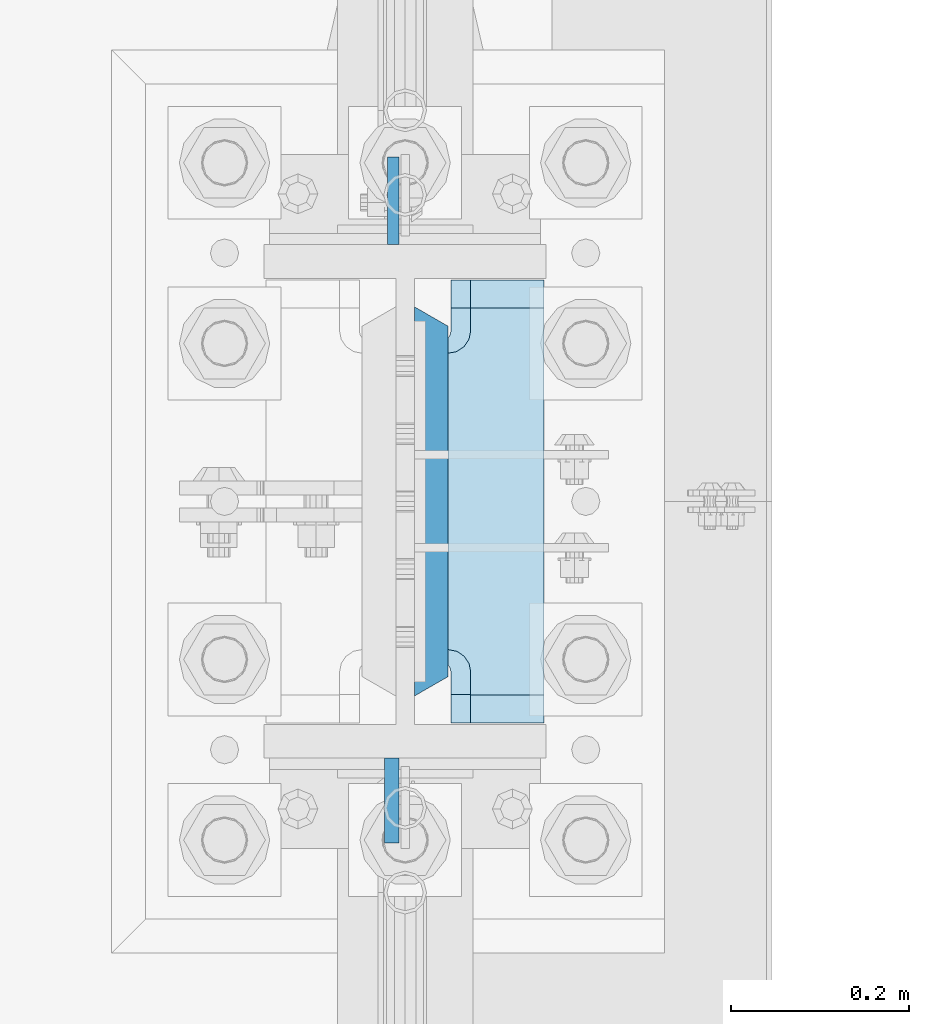
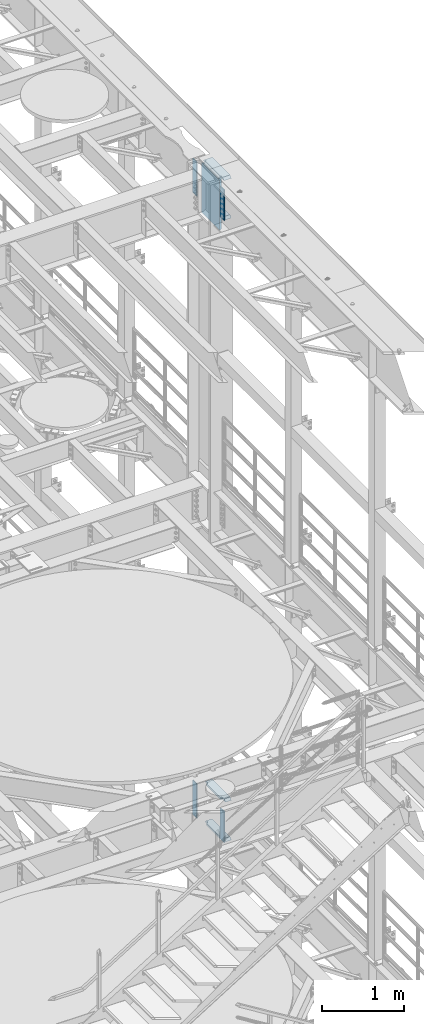
# One storey, part 1675 of 1876: 9 plates, 2 elements without a shape of their own.
"""IFC2X3 building model written with IfcOpenShell, lengths in millimetres."""

from ifc_helpers import new_model, si_unit, frame, origin_with_axes, place, context, subcontext, project, spatial, faceted_brep, material, type_object, element, aggregate, save


model = new_model("IFC2X3")

# Units and contexts
model_context = context("Model", 3, precision=1e-05, world=origin_with_axes())
body_context = subcontext(model_context, "Body", "Model", "MODEL_VIEW")
ifc_project = project(units=[si_unit("LENGTHUNIT", "METRE", prefix="MILLI"), si_unit("AREAUNIT", "SQUARE_METRE"), si_unit("VOLUMEUNIT", "CUBIC_METRE"), si_unit("MASSUNIT", "GRAM", prefix="KILO"), si_unit("TIMEUNIT", "SECOND"), si_unit("PLANEANGLEUNIT", "RADIAN"), si_unit("SOLIDANGLEUNIT", "STERADIAN"), si_unit("THERMODYNAMICTEMPERATUREUNIT", "DEGREE_CELSIUS"), si_unit("LUMINOUSINTENSITYUNIT", "LUMEN")], contexts=[model_context])

# Site, building, storey
site_placement = place(None, origin_with_axes())
site = spatial("IfcSite", under=ifc_project, at=site_placement, CompositionType="ELEMENT")
building_placement = place(site_placement, origin_with_axes())
building = spatial("IfcBuilding", under=site, at=building_placement, Name="Undefined", CompositionType="ELEMENT")
storey_placement = place(building_placement, origin_with_axes())
storey = spatial("IfcBuildingStorey", under=building, at=storey_placement, Name="Undefined", CompositionType="ELEMENT", Elevation=0.0)

# Assembly, plate
assembly_1_placement = place(storey_placement, origin_with_axes())
assembly_1 = element("IfcElementAssembly", 1, at=assembly_1_placement, inside=storey, Name="COLUMN", AssemblyPlace="NOTDEFINED", PredefinedType="RIGID_FRAME")
ifc_material_1 = material(Name="STEEL/A572-50")
plate_type_1 = type_object("IfcPlateType", PredefinedType="NOTDEFINED")
plate_1_placement = place(assembly_1_placement, frame((7606.50699987411, 1812.925, 22501.225), z_axis=(0.0, 1.0, 0.0), x_axis=(0.0, 0.0, -1.0)))
plate_1 = element("IfcPlate", 2, at=plate_1_placement, type_object=plate_type_1, material=ifc_material_1, Name="PLATE", context=body_context, shape_type="Brep", body=[
    faceted_brep([(0.0, -6.35000000000036, 0.0), (0.0, -6.34999999999991, 98.4250030517578), (0.0, 6.34999999999991, 98.4250030517578), (0.0, 6.35000000000036, 0.0), (514.349975585938, -6.35000000000036, 98.4250030517578), (514.349975585938, 6.35000000000036, 98.4250030517578), (514.349975585938, -6.35000000000036, 0.0), (514.349975585938, 6.35000000000036, 0.0)], [[[0, 1, 2, 3]], [[1, 4, 5, 2]], [[4, 6, 7, 5]], [[6, 0, 3, 7]], [[5, 7, 3, 2]], [[6, 4, 1, 0]]]),
])

assembly_2_placement = place(storey_placement, origin_with_axes())
assembly_2 = element("IfcElementAssembly", 3, at=assembly_2_placement, inside=storey, Name="COLUMN", AssemblyPlace="NOTDEFINED", PredefinedType="RIGID_FRAME")
plate_2_placement = place(assembly_2_placement, frame((7606.50699987411, 1812.925, 13255.625), z_axis=(0.0, 1.0, 0.0), x_axis=(0.0, 0.0, -1.0)))
plate_2 = element("IfcPlate", 4, at=plate_2_placement, type_object=plate_type_1, material=ifc_material_1, Name="PLATE", context=body_context, shape_type="Brep", body=[
    faceted_brep([(0.0, -6.35000000000036, 0.0), (0.0, -6.34999999999991, 98.4250030517578), (0.0, 6.34999999999991, 98.4250030517578), (0.0, 6.35000000000036, 0.0), (514.349975585938, -6.35000000000036, 98.4250030517578), (514.349975585938, 6.35000000000036, 98.4250030517578), (514.349975585938, -6.35000000000036, 0.0), (514.349975585938, 6.35000000000036, 0.0)], [[[0, 1, 2, 3]], [[1, 4, 5, 2]], [[4, 6, 7, 5]], [[6, 0, 3, 7]], [[5, 7, 3, 2]], [[6, 4, 1, 0]]]),
])

# Plate
ifc_material_2 = material(Name="STEEL/A572-GR.50")
plate_type_2 = type_object("IfcPlateType", PredefinedType="NOTDEFINED")
plate_3_placement = place(assembly_1_placement, frame((7649.36875, 1304.925, 22523.45), z_axis=(0.0, 1.0, 0.0), x_axis=(0.0, 0.0, -1.0)))
plate_3 = element("IfcPlate", 5, at=plate_3_placement, type_object=plate_type_2, material=ifc_material_2, Name="PLATE", context=body_context, shape_type="Brep", body=[
    faceted_brep([(0.0, -19.0500000000002, 416.152954749452), (742.950012207031, -19.0500000000002, 416.152954749372), (742.950012207031, 19.0500000000002, 438.149993896484), (0.0, 19.0500000000002, 438.149993896484), (742.950012207031, -19.0500000000002, 21.9970452506512), (742.950012207031, 19.0500000000002, 0.0), (-9.09494701772928e-13, 19.05, -1.81898940354586e-12), (0.0, -19.0500000000002, 21.9970452506512)], [[[0, 1, 2, 3]], [[2, 1, 4, 5]], [[3, 2, 5, 6]], [[0, 3, 6, 7]], [[1, 0, 7, 4]], [[6, 5, 4, 7]]]),
])

plate_type_3 = type_object("IfcPlateType", PredefinedType="NOTDEFINED")
plate_4_placement = place(assembly_1_placement, frame((7604.91949987411, 1235.075, 22491.7), z_axis=(0.0, -1.0, 0.0), x_axis=(0.0, 0.0, -1.0)))
plate_4 = element("IfcPlate", 6, at=plate_4_placement, type_object=plate_type_3, material=ifc_material_1, Name="PLATE", context=body_context, shape_type="Brep", body=[
    faceted_brep([(0.0, -7.9375, 0.0), (0.0, -7.9375, 95.25), (0.0, 7.9375, 95.25), (0.0, 7.9375, 0.0), (457.200012207031, -7.9375, 95.25), (457.200012207031, 7.9375, 95.25), (457.200012207031, -7.9375, 0.0), (457.200012207031, 7.9375, 0.0)], [[[0, 1, 2, 3]], [[1, 4, 5, 2]], [[4, 6, 7, 5]], [[6, 0, 3, 7]], [[5, 7, 3, 2]], [[6, 4, 1, 0]]]),
])

ifc_material_3 = material(Name="STEEL/A36")
plate_5_placement = place(assembly_2_placement, frame((7604.91949987411, 1235.075, 13246.1), z_axis=(0.0, -1.0, 0.0), x_axis=(0.0, 0.0, -1.0)))
plate_5 = element("IfcPlate", 7, at=plate_5_placement, type_object=plate_type_3, material=ifc_material_3, Name="PLATE", context=body_context, shape_type="Brep", body=[
    faceted_brep([(0.0, -7.9375, 0.0), (0.0, -7.9375, 95.25), (0.0, 7.9375, 95.25), (0.0, 7.9375, 0.0), (457.200012207031, -7.9375, 95.25), (457.200012207031, 7.9375, 95.25), (457.200012207031, -7.9375, 0.0), (457.200012207031, 7.9375, 0.0)], [[[0, 1, 2, 3]], [[1, 4, 5, 2]], [[4, 6, 7, 5]], [[6, 0, 3, 7]], [[5, 7, 3, 2]], [[6, 4, 1, 0]]]),
])

plate_type_4 = type_object("IfcPlateType", PredefinedType="NOTDEFINED")
plate_6_placement = place(assembly_1_placement, frame((7668.41875, 1773.2375, 21948.775012207), z_axis=(0.0, -1.0, 0.0), x_axis=(1.0, 0.0, 0.0)))
plate_6 = element("IfcPlate", 8, at=plate_6_placement, type_object=plate_type_4, material=ifc_material_1, Name="PLATE", context=body_context, shape_type="Brep", body=[
    faceted_brep([(107.949996948242, -15.875, 498.475006103516), (107.949996948242, 15.875, 467.025007631571), (25.3999996185303, 15.875, 467.025007631571), (25.3999996185303, -15.875, 498.475006103516), (23.4665397733561, -15.875, 431.604843634198), (25.3999996185303, -15.875, 441.325002670288), (25.3999996185303, 15.875, 441.325002670288), (23.4665397733561, 15.875, 431.604843634198), (17.9605119724001, -15.875, 423.36449069789), (17.9605119724001, 15.875, 423.36449069789), (9.72015903609281, -15.875, 417.858462896934), (9.72015903609281, 15.875, 417.858462896934), (0.0, -15.875, 415.925003051758), (0.0, 15.875, 415.925003051758), (0.0, -15.875, 82.5500030517578), (0.0, 15.875, 82.5500030517578), (9.72015903609099, -15.875, 80.616543206582), (9.72015903609099, 15.875, 80.616543206582), (17.9605119723983, -15.875, 75.1105154056258), (17.9605119723983, 15.875, 75.1105154056258), (23.4665397733552, -15.875, 66.8701624693183), (23.4665397733552, 15.875, 66.8701624693183), (25.3999996185303, -15.875, 57.1500034332275), (25.3999996185303, 15.875, 57.1500034332275), (25.3999996185303, 15.875, 31.449998471945), (25.3999996185303, -15.875, 0.0), (107.949996948242, 15.875, 31.449998471945), (107.949996948242, -15.875, 0.0)], [[[0, 1, 2, 3]], [[4, 5, 6, 7]], [[8, 4, 7, 9]], [[10, 8, 9, 11]], [[12, 10, 11, 13]], [[14, 12, 13, 15]], [[16, 14, 15, 17]], [[18, 16, 17, 19]], [[20, 18, 19, 21]], [[22, 20, 21, 23]], [[22, 23, 24, 25]], [[26, 27, 25, 24]], [[5, 4, 8, 10, 12, 14, 16, 18, 20, 22, 25, 27, 0, 3]], [[6, 5, 3, 2]], [[26, 24, 23, 21, 19, 17, 15, 13, 11, 9, 7, 6, 2, 1]], [[27, 26, 1, 0]]]),
])

plate_7_placement = place(assembly_2_placement, frame((7668.41875, 1773.2375, 12703.175012207), z_axis=(0.0, -1.0, 0.0), x_axis=(1.0, 0.0, 0.0)))
plate_7 = element("IfcPlate", 9, at=plate_7_placement, type_object=plate_type_4, material=ifc_material_1, Name="PLATE", context=body_context, shape_type="Brep", body=[
    faceted_brep([(107.949996948242, -15.875, 498.475006103516), (107.949996948242, 15.875, 467.025007631571), (25.3999996185303, 15.875, 467.025007631571), (25.3999996185303, -15.875, 498.475006103516), (23.4665397733561, -15.875, 431.604843634198), (25.3999996185303, -15.875, 441.325002670288), (25.3999996185303, 15.875, 441.325002670288), (23.4665397733561, 15.875, 431.604843634198), (17.9605119724001, -15.875, 423.36449069789), (17.9605119724001, 15.875, 423.36449069789), (9.72015903609281, -15.875, 417.858462896934), (9.72015903609281, 15.875, 417.858462896934), (0.0, -15.875, 415.925003051758), (0.0, 15.875, 415.925003051758), (0.0, -15.875, 82.5500030517578), (0.0, 15.875, 82.5500030517578), (9.72015903609099, -15.875, 80.616543206582), (9.72015903609099, 15.875, 80.616543206582), (17.9605119723983, -15.875, 75.1105154056258), (17.9605119723983, 15.875, 75.1105154056258), (23.4665397733552, -15.875, 66.8701624693183), (23.4665397733552, 15.875, 66.8701624693183), (25.3999996185303, -15.875, 57.1500034332275), (25.3999996185303, 15.875, 57.1500034332275), (25.3999996185303, 15.875, 31.449998471945), (25.3999996185303, -15.875, 0.0), (107.949996948242, 15.875, 31.449998471945), (107.949996948242, -15.875, 0.0)], [[[0, 1, 2, 3]], [[4, 5, 6, 7]], [[8, 4, 7, 9]], [[10, 8, 9, 11]], [[12, 10, 11, 13]], [[14, 12, 13, 15]], [[16, 14, 15, 17]], [[18, 16, 17, 19]], [[20, 18, 19, 21]], [[22, 20, 21, 23]], [[22, 23, 24, 25]], [[26, 27, 25, 24]], [[5, 4, 8, 10, 12, 14, 16, 18, 20, 22, 25, 27, 0, 3]], [[6, 5, 3, 2]], [[26, 24, 23, 21, 19, 17, 15, 13, 11, 9, 7, 6, 2, 1]], [[27, 26, 1, 0]]]),
])

plate_8_placement = place(assembly_2_placement, frame((7668.41875, 1773.2375, 13293.725), z_axis=(0.0, -1.0, 0.0), x_axis=(1.0, 0.0, 0.0)))
plate_8 = element("IfcPlate", 10, at=plate_8_placement, type_object=plate_type_4, material=ifc_material_1, Name="PLATE", context=body_context, shape_type="Brep", body=[
    faceted_brep([(107.949996948242, -15.875, 498.475006103516), (107.949996948242, 15.875, 467.025007631571), (25.3999996185303, 15.875, 467.025007631571), (25.3999996185303, -15.875, 498.475006103516), (23.4665397733561, -15.875, 431.604843634198), (25.3999996185303, -15.875, 441.325002670288), (25.3999996185303, 15.875, 441.325002670288), (23.4665397733561, 15.875, 431.604843634198), (17.9605119724001, -15.875, 423.36449069789), (17.9605119724001, 15.875, 423.36449069789), (9.72015903609281, -15.875, 417.858462896934), (9.72015903609281, 15.875, 417.858462896934), (0.0, -15.875, 415.925003051758), (0.0, 15.875, 415.925003051758), (0.0, -15.875, 82.5500030517578), (0.0, 15.875, 82.5500030517578), (9.72015903609099, -15.875, 80.616543206582), (9.72015903609099, 15.875, 80.616543206582), (17.9605119723983, -15.875, 75.1105154056258), (17.9605119723983, 15.875, 75.1105154056258), (23.4665397733552, -15.875, 66.8701624693183), (23.4665397733552, 15.875, 66.8701624693183), (25.3999996185303, -15.875, 57.1500034332275), (25.3999996185303, 15.875, 57.1500034332275), (25.3999996185303, 15.875, 31.449998471945), (25.3999996185303, -15.875, 0.0), (107.949996948242, 15.875, 31.449998471945), (107.949996948242, -15.875, 0.0)], [[[0, 1, 2, 3]], [[4, 5, 6, 7]], [[8, 4, 7, 9]], [[10, 8, 9, 11]], [[12, 10, 11, 13]], [[14, 12, 13, 15]], [[16, 14, 15, 17]], [[18, 16, 17, 19]], [[20, 18, 19, 21]], [[22, 20, 21, 23]], [[22, 23, 24, 25]], [[26, 27, 25, 24]], [[5, 4, 8, 10, 12, 14, 16, 18, 20, 22, 25, 27, 0, 3]], [[6, 5, 3, 2]], [[26, 24, 23, 21, 19, 17, 15, 13, 11, 9, 7, 6, 2, 1]], [[27, 26, 1, 0]]]),
])

aggregate(assembly_2, [plate_2, plate_5, plate_7, plate_8])

plate_type_5 = type_object("IfcPlateType", PredefinedType="NOTDEFINED")
plate_9_placement = place(assembly_1_placement, frame((7776.36874694824, 1274.7625, 22539.325), z_axis=(0.0, 1.0, 0.0), x_axis=(-1.0, 0.0, 0.0)))
plate_9 = element("IfcPlate", 11, at=plate_9_placement, type_object=plate_type_5, material=ifc_material_1, Name="PLATE", context=body_context, shape_type="Brep", body=[
    faceted_brep([(108.494745348945, -15.875, 66.1302546510551), (108.494745348945, 15.875, 66.1302546510551), (112.614921817099, 15.875, 68.8832685515335), (112.614921817099, -15.875, 68.8832685515335), (105.741731448466, -15.875, 62.0100781829015), (105.741731448466, 15.875, 62.0100781829015), (104.775001525879, -15.875, 57.149998664856), (104.775001525879, 15.875, 57.149998664856), (104.775001525879, -15.875, 0.0), (104.775001525879, 15.875, 31.75), (0.0, -15.875, 0.0), (0.0, 15.875, 31.75), (0.0, -15.875, 498.475006103516), (0.0, 15.875, 466.725006103516), (104.775001525879, -15.875, 498.475006103516), (104.775001525879, 15.875, 466.725006103516), (104.775001525879, -15.875, 441.325001335143), (104.775001525879, 15.875, 441.325001335143), (105.741731448466, -15.875, 436.464921817097), (105.741731448466, 15.875, 436.464921817097), (108.494745348945, -15.875, 432.344745348943), (108.494745348945, 15.875, 432.344745348943), (112.614921817099, -15.875, 429.591731448465), (112.614921817099, 15.875, 429.591731448465), (117.475001335144, -15.875, 428.625001525877), (146.050003051758, -15.875, 428.625001525877), (117.475001335144, 12.6998335648605, 428.625001525877), (114.299816893596, 15.875, 429.256584980013), (114.299816893596, 15.875, 69.2184150199857), (117.475001335144, -15.875, 69.8499984741211), (117.475001335144, 12.6998335648605, 69.8499984741211), (146.050003051758, -15.875, 69.8499984741211)], [[[0, 1, 2, 3]], [[4, 5, 1, 0]], [[6, 7, 5, 4]], [[8, 9, 7, 6]], [[10, 11, 9, 8]], [[11, 10, 12, 13]], [[13, 12, 14, 15]], [[14, 16, 17, 15]], [[18, 19, 17, 16]], [[20, 21, 19, 18]], [[22, 23, 21, 20]], [[24, 25, 26]], [[23, 22, 24, 26, 27]], [[2, 1, 5, 7, 9, 11, 13, 15, 17, 19, 21, 23, 27, 28]], [[29, 3, 2, 28, 30]], [[29, 30, 31]], [[24, 22, 20, 18, 16, 14, 12, 10, 8, 6, 4, 0, 3, 29, 31, 25]], [[30, 28, 27, 26, 25, 31]]]),
])

aggregate(assembly_1, [plate_6, plate_3, plate_1, plate_4, plate_9])

save(model, "model.ifc")
